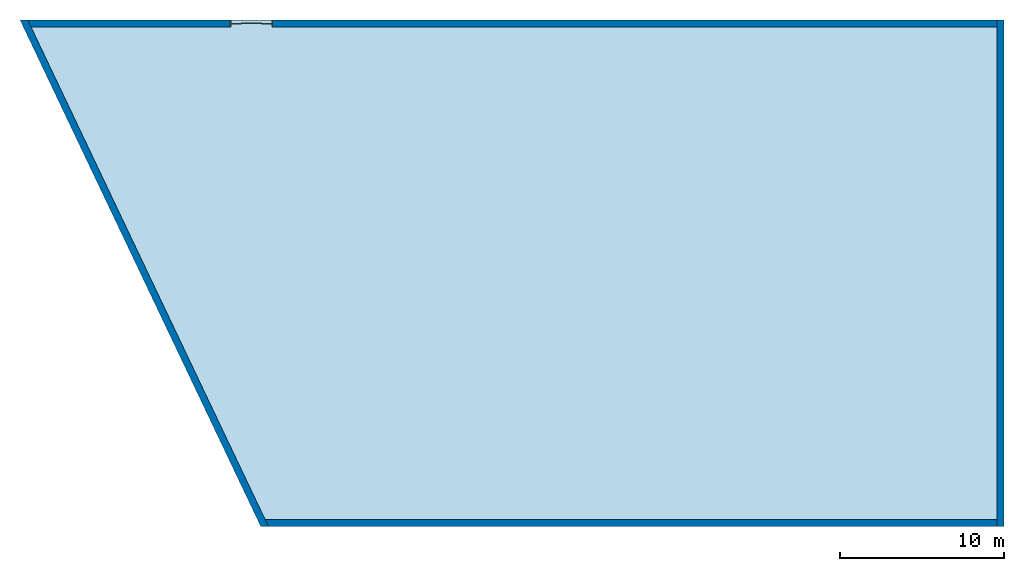
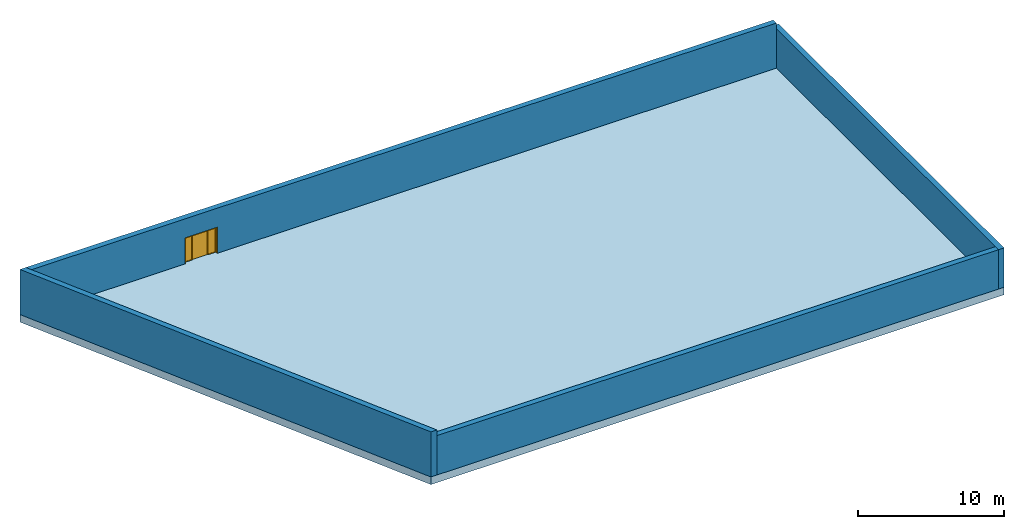
# One storey: 4 walls, 1 door, 1 slab, 1 opening.
"""IFC2X3 building model written with IfcOpenShell, lengths in metres."""

from ifc_helpers import new_model, entity, si_unit, converted_unit, derived_unit, direction, frame, frame_2d, origin, origin_2d_with_axis, place, context, subcontext, project, spatial, polyline, rectangle, outline, extrude, faceted_brep, source, transform, mapped, material, material_list, layer, layer_set, layer_usage, type_object, type_shapes, element, fill, save


model = new_model("IFC2X3")

# Units and contexts
model_context = context("Model", 3, precision=1e-05, world=origin(), true_north=direction((6.123031769111886e-17, 1.0)))
body_context = subcontext(model_context, "Body", "Model", "MODEL_VIEW")
ifc_project = project(units=[si_unit("LENGTHUNIT", "METRE"), si_unit("AREAUNIT", "SQUARE_METRE"), si_unit("VOLUMEUNIT", "CUBIC_METRE"), converted_unit("PLANEANGLEUNIT", "DEGREE", entity("IfcRatioMeasure", 0.017453292519943278), si_unit("PLANEANGLEUNIT", "RADIAN"), dimensions=[0, 0, 0, 0, 0, 0, 0]), si_unit("MASSUNIT", "GRAM", prefix="KILO"), derived_unit("MASSDENSITYUNIT", [(si_unit("MASSUNIT", "GRAM", prefix="KILO"), 1), (si_unit("LENGTHUNIT", "METRE"), -3)]), derived_unit("IONCONCENTRATIONUNIT", [(si_unit("MASSUNIT", "GRAM", prefix="KILO"), 1), (si_unit("LENGTHUNIT", "METRE"), -3)]), derived_unit("MOMENTOFINERTIAUNIT", [(si_unit("LENGTHUNIT", "METRE"), 4)]), si_unit("TIMEUNIT", "SECOND"), si_unit("FREQUENCYUNIT", "HERTZ"), si_unit("THERMODYNAMICTEMPERATUREUNIT", "DEGREE_CELSIUS"), derived_unit("THERMALTRANSMITTANCEUNIT", [(si_unit("MASSUNIT", "GRAM", prefix="KILO"), 1), (si_unit("THERMODYNAMICTEMPERATUREUNIT", "KELVIN"), -1), (si_unit("TIMEUNIT", "SECOND"), -3)]), derived_unit("THERMALCONDUCTANCEUNIT", [(si_unit("MASSUNIT", "GRAM", prefix="KILO"), 1), (si_unit("THERMODYNAMICTEMPERATUREUNIT", "KELVIN"), -1), (si_unit("TIMEUNIT", "SECOND"), -3), (si_unit("LENGTHUNIT", "METRE"), 1)]), derived_unit("VOLUMETRICFLOWRATEUNIT", [(si_unit("LENGTHUNIT", "METRE"), 3), (si_unit("TIMEUNIT", "SECOND"), -1)]), derived_unit("MASSFLOWRATEUNIT", [(si_unit("MASSUNIT", "GRAM", prefix="KILO"), 1), (si_unit("TIMEUNIT", "SECOND"), -1)]), derived_unit("ROTATIONALFREQUENCYUNIT", [(si_unit("TIMEUNIT", "SECOND"), -1)]), si_unit("ELECTRICCURRENTUNIT", "AMPERE"), si_unit("ELECTRICVOLTAGEUNIT", "VOLT"), si_unit("POWERUNIT", "WATT"), si_unit("FORCEUNIT", "NEWTON", prefix="KILO"), si_unit("ILLUMINANCEUNIT", "LUX"), si_unit("LUMINOUSFLUXUNIT", "LUMEN"), si_unit("LUMINOUSINTENSITYUNIT", "CANDELA"), derived_unit("USERDEFINED", [(si_unit("MASSUNIT", "GRAM", prefix="KILO"), -1), (si_unit("LENGTHUNIT", "METRE"), -2), (si_unit("TIMEUNIT", "SECOND"), 3), (si_unit("LUMINOUSFLUXUNIT", "LUMEN"), 1)]), derived_unit("USERDEFINED", [(si_unit("MASSUNIT", "GRAM", prefix="KILO"), 1), (si_unit("TIMEUNIT", "SECOND"), -3), (si_unit("LENGTHUNIT", "METRE"), 3), (si_unit("ELECTRICCURRENTUNIT", "AMPERE"), -2)]), derived_unit("SOUNDPOWERUNIT", [(si_unit("MASSUNIT", "GRAM", prefix="KILO"), 1), (si_unit("TIMEUNIT", "SECOND"), -3), (si_unit("LENGTHUNIT", "METRE"), 2)]), derived_unit("SOUNDPRESSUREUNIT", [(si_unit("MASSUNIT", "GRAM", prefix="KILO"), 1), (si_unit("LENGTHUNIT", "METRE"), -1), (si_unit("TIMEUNIT", "SECOND"), -2)]), derived_unit("LINEARVELOCITYUNIT", [(si_unit("LENGTHUNIT", "METRE"), 1), (si_unit("TIMEUNIT", "SECOND"), -1)]), si_unit("PRESSUREUNIT", "PASCAL"), derived_unit("USERDEFINED", [(si_unit("MASSUNIT", "GRAM", prefix="KILO"), 1), (si_unit("LENGTHUNIT", "METRE"), -2), (si_unit("TIMEUNIT", "SECOND"), -2)]), derived_unit("LINEARFORCEUNIT", [(si_unit("MASSUNIT", "GRAM", prefix="KILO"), 1), (si_unit("TIMEUNIT", "SECOND"), -2)]), derived_unit("PLANARFORCEUNIT", [(si_unit("MASSUNIT", "GRAM", prefix="KILO"), 1), (si_unit("LENGTHUNIT", "METRE"), -1), (si_unit("TIMEUNIT", "SECOND"), -2)]), derived_unit("SPECIFICHEATCAPACITYUNIT", [(si_unit("THERMODYNAMICTEMPERATUREUNIT", "KELVIN"), -1), (si_unit("LENGTHUNIT", "METRE"), 2), (si_unit("TIMEUNIT", "SECOND"), -2)]), derived_unit("HEATINGVALUEUNIT", [(si_unit("LENGTHUNIT", "METRE"), 2), (si_unit("TIMEUNIT", "SECOND"), -2)]), derived_unit("VAPORPERMEABILITYUNIT", [(si_unit("LENGTHUNIT", "METRE"), -1), (si_unit("TIMEUNIT", "SECOND"), 1)]), derived_unit("DYNAMICVISCOSITYUNIT", [(si_unit("MASSUNIT", "GRAM", prefix="KILO"), 1), (si_unit("TIMEUNIT", "SECOND"), -1), (si_unit("LENGTHUNIT", "METRE"), -1)]), derived_unit("THERMALEXPANSIONCOEFFICIENTUNIT", [(si_unit("THERMODYNAMICTEMPERATUREUNIT", "KELVIN"), -1)]), derived_unit("MODULUSOFELASTICITYUNIT", [(si_unit("MASSUNIT", "GRAM", prefix="KILO"), 1), (si_unit("LENGTHUNIT", "METRE"), -1), (si_unit("TIMEUNIT", "SECOND"), -2)]), derived_unit("ISOTHERMALMOISTURECAPACITYUNIT", [(si_unit("LENGTHUNIT", "METRE"), 3), (si_unit("MASSUNIT", "GRAM", prefix="KILO"), -1)]), derived_unit("MOISTUREDIFFUSIVITYUNIT", [(si_unit("TIMEUNIT", "SECOND"), -1), (si_unit("LENGTHUNIT", "METRE"), 2)])], contexts=[model_context])

# Site, building, storey
site_placement = place(None, frame((83.18260837531514, 5.722313863433043, -0.3219974716737357), z_axis=(0.0, 0.0, 1.0), x_axis=(0.31599863684750407, -0.9487596436982969, 0.0)))
site = spatial("IfcSite", under=ifc_project, at=site_placement, CompositionType="ELEMENT")
building_placement = place(site_placement, origin())
building = spatial("IfcBuilding", under=site, at=building_placement, CompositionType="ELEMENT")
storey_placement = place(building_placement, frame((0.0, 0.0, -7.478002528326264)))
storey = spatial("IfcBuildingStorey", under=building, at=storey_placement, CompositionType="ELEMENT", Elevation=-7.478002528326264)

# Slab
ifc_material_1 = material()
ifc_layer_1 = layer(ifc_material_1, 0.005)
ifc_material_2 = material()
ifc_layer_2 = layer(ifc_material_2, 0.08)
ifc_material_3 = material()
ifc_layer_3 = layer(ifc_material_3, 0.2)
ifc_material_4 = material()
ifc_layer_4 = layer(ifc_material_4, 0.35)
ifc_layer_set_1 = layer_set([ifc_layer_1, ifc_layer_2, ifc_layer_3, ifc_layer_4])
ifc_layer_usage_1 = layer_usage(ifc_layer_set_1, "AXIS3", "POSITIVE", 0.0)
slab_type = type_object("IfcSlabType", PredefinedType="FLOOR", material=ifc_layer_set_1)
slab_placement = place(storey_placement, origin())
element("IfcSlab", 1, at=slab_placement, inside=storey, type_object=slab_type, material=ifc_layer_usage_1, PredefinedType="FLOOR", context=body_context, shape_type="SweptSolid", body=[
    extrude(outline(polyline([(-15.437583681632269, -26.331015801751978), (15.437583682817348, -26.331015801751978), (15.437583682817426, 18.993704010185013), (-15.437583684002513, 33.66832759331895), (-15.437583681632269, -26.331015801751978)])), frame((-16.178200656982813, -52.623733880741646, 0.0), z_axis=(0.0, 0.0, -1.0), x_axis=(0.9487590375396322, -0.31600045678269334, 0.0)), (0.0, 0.0, 1.0), 0.6349999999999997),
])

# Walls
ifc_layer_5 = layer(ifc_material_4, 0.29999999999999993)
ifc_material_5 = material(Name="Rigid insulation")
ifc_layer_6 = layer(ifc_material_5, 0.12499999999999999)
ifc_layer_set_2 = layer_set([ifc_layer_5, ifc_layer_6], Name="Basic Wall:CAVE_M-cave-01 (")
ifc_layer_usage_2 = layer_usage(ifc_layer_set_2, "AXIS2", "NEGATIVE", 0.21249999999999994)
wall_type = type_object("IfcWallType", Name="Basic Wall:CAVE_M-cave-01 (", PredefinedType="STANDARD", material=ifc_layer_set_2)
wall_1_placement = place(storey_placement, frame((6.721809303704131, -32.72183946209911, 0.0), z_axis=(0.0, 0.0, 1.0), x_axis=(-0.9487590375396322, 0.3160004567826936, 0.0)))
element("IfcWallStandardCase", 2, at=wall_1_placement, inside=storey, type_object=wall_type, material=ifc_layer_usage_2, Name="Basic Wall:CAVE_M-cave-01 (", ObjectType="Basic Wall:CAVE_M-cave-01 (", context=body_context, shape_type="SweptSolid", body=[
    extrude(rectangle(XDim=30.875167364449617, YDim=0.42499999999999544, at=frame_2d((2.800426557314495e-12, -0.0708333333333305), x_axis=(1.0, 0.0))), frame((15.43758368223041, 0.07083333333333455, 0.0)), (0.0, 0.0, 1.0), 3.2899999999999974),
])
wall_2_placement = place(storey_placement, frame((-41.489851829026286, -79.47766441075834, 0.0), z_axis=(0.0, 0.0, 1.0), x_axis=(0.992546151641322, 0.12186934340514734, 0.0)))
element("IfcWallStandardCase", 3, at=wall_2_placement, inside=storey, type_object=wall_type, material=ifc_layer_usage_2, Name="Basic Wall:CAVE_M-cave-01 (", ObjectType="Basic Wall:CAVE_M-cave-01 (", context=body_context, shape_type="SweptSolid", body=[
    extrude(outline(polyline([(-17.227211343700098, -0.2833333333334054), (16.9578809808178, -0.28333333333326705), (17.159878752967014, 0.14166666666674113), (16.689317279880626, 0.14166666666674274), (-16.55465209843506, 0.14166666666660901), (-17.02521357153029, 0.14166666666661415), (-17.227211343700098, -0.2833333333334054)])), frame((17.227211343700098, 0.07083333333334323, 0.0)), (0.0, 0.0, 1.0), 3.7699999999999974),
])
wall_3_placement = place(storey_placement, frame((-7.650417806654925, -75.2005133766632, 0.0), z_axis=(0.0, 0.0, 1.0), x_axis=(0.31600045678269195, 0.9487590375396326, 0.0)))
element("IfcWallStandardCase", 4, at=wall_3_placement, inside=storey, type_object=wall_type, material=ifc_layer_usage_2, Name="Basic Wall:CAVE_M-cave-01 (", ObjectType="Basic Wall:CAVE_M-cave-01 (", context=body_context, shape_type="SweptSolid", body=[
    extrude(outline(polyline([(-22.164079726387982, -0.2124999999996669), (22.265078612462588, -0.2125000000003307), (22.265078612462588, 0.21249999999966582), (-22.366077498537194, 0.2125000000003307), (-22.164079726387982, -0.2124999999996669)])), frame((22.36607749853719, 0.0, 0.0)), (0.0, 0.0, 1.0), 3.2899999999999974),
])

# Wall, opening, door
wall_4_placement = place(storey_placement, frame((-22.43682357046857, -23.234033864221146, 0.0), z_axis=(0.0, 0.0, 1.0), x_axis=(-0.3160004568201735, -0.9487590375271486, 0.0)))
wall_4 = element("IfcWall", 5, at=wall_4_placement, inside=storey, type_object=wall_type, Name="Basic Wall:CAVE_M-cave-01 (", ObjectType="Basic Wall:CAVE_M-cave-01 (", context=body_context, shape_type="Brep", body=[
    faceted_brep([(0.0, -0.21249999999999933, 0.0), (0.0, 0.21250000000000258, 0.0), (44.17999999992445, 0.212499999999982, 0.0), (44.179999999924455, -0.212499999999995, 0.0), (59.10378192199245, -0.21250000000000366, 3.7699999999999996), (0.0, -0.21249999999999933, 3.7699999999999996), (0.0, -0.21249999999999933, 3.289999999999999), (44.179999999924455, -0.212499999999995, 2.183), (46.75999999992445, -0.212499999999995, 2.183), (46.75999999992445, -0.21249999999999933, 0.0), (59.10378192199245, -0.212499999999995, 0.0), (58.90178414982267, 0.21250000000000802, 3.7699999999999996), (0.0, 0.21250000000000258, 3.7699999999999996), (58.90178414982267, 0.21249999999999933, 0.0), (46.75999999992445, 0.21249999999999933, 0.0), (46.75999999992445, 0.21249999999999933, 2.183), (44.179999999924455, 0.21250000000000802, 2.183)], [[[0, 1, 2, 3]], [[4, 5, 6, 0, 3, 7, 8, 9, 10]], [[5, 4, 11, 12]], [[12, 11, 13, 14, 15, 16, 2, 1]], [[13, 11, 4, 10]], [[8, 15, 14, 9]], [[15, 8, 7, 16]], [[16, 7, 3, 2]], [[1, 0, 6, 5, 12]], [[13, 10, 9, 14]]]),
])
opening_placement = place(wall_4_placement, frame((46.75999999992447, 0.21249999999999933, 0.0)))
opening = element("IfcOpeningElement", 6, at=opening_placement, cuts=wall_4, Name="Sliding Door - 4 Panel (AUS):Type 1:1", ObjectType="Opening", context=body_context, shape_type="SweptSolid", body=[
    extrude(rectangle(XDim=2.1830000000000003, YDim=2.5799999999999996, at=frame_2d((1.0915000000000004, 1.2900000000000011), x_axis=(1.0, 0.0))), frame((0.0, 0.0, 0.0), z_axis=(0.0, -1.0, 0.0), x_axis=(0.0, 0.0, 1.0)), (0.0, 0.0, 1.0), 0.4249999999999999),
])
ifc_material_6 = material(Name="Sliding Door Glass")
ifc_material_7 = material(Name="Sliding Door Frame")
ifc_material_list = material_list([ifc_material_6, ifc_material_7])
door_style = type_object("IfcDoorStyle", Name="Sliding Door - 4 Panel (AUS):Type 1", ConstructionType="NOTDEFINED", OperationType="NOTDEFINED", ParameterTakesPrecedence=False, Sizeable=False, material=ifc_material_list)
shared_shape = source(origin(), body_context, "Body", "SweptSolid", [
    extrude(rectangle(XDim=0.5287499999999998, YDim=0.01333333333333333, at=frame_2d((-8.326672684688674e-17, 0.0), x_axis=(1.0, 0.0))), frame((2.2206249999999987, 0.19249999999999995, 0.05499999999999999), z_axis=(0.0, 0.0, 1.0), x_axis=(-1.0, 0.0, 0.0)), (0.0, 0.0, 1.0), 2.0329999999999995),
    extrude(outline(polyline([(-0.31937499999999996, -1.0715), (0.3193749999999998, -1.0715), (0.31937499999999996, 1.0715), (-0.31937499999999996, 1.0715), (-0.31937499999999996, -1.0715)]), holes=[polyline([(-0.264375, -1.0164999999999997), (-0.264375, 1.0164999999999997), (0.26437499999999986, 1.0164999999999997), (0.26437499999999986, -1.0164999999999997), (-0.264375, -1.0164999999999997)])]), frame((2.2206249999999987, 0.1725, 1.0715), z_axis=(0.0, 1.0, 0.0), x_axis=(-1.0, 0.0, 0.0)), (0.0, 0.0, 1.0), 0.039999999999999994),
    extrude(rectangle(XDim=0.5287499999999997, YDim=0.01333333333333333, at=frame_2d((-2.7755575615628914e-17, 0.0), x_axis=(1.0, 0.0))), frame((1.609374999999998, 0.23249999999999993, 0.05499999999999999), z_axis=(0.0, 0.0, 1.0), x_axis=(-1.0, 0.0, 0.0)), (0.0, 0.0, 1.0), 2.0329999999999995),
    extrude(outline(polyline([(-0.31937499999999996, -1.0715), (0.3193749999999998, -1.0715), (0.31937499999999996, 1.0715), (-0.3193749999999998, 1.0715), (-0.31937499999999996, -1.0715)]), holes=[polyline([(-0.26437499999999986, -1.0164999999999997), (-0.26437499999999986, 1.0164999999999997), (0.26437499999999986, 1.0164999999999997), (0.26437499999999986, -1.0164999999999997), (-0.26437499999999986, -1.0164999999999997)])]), frame((1.609374999999998, 0.21249999999999994, 1.0715), z_axis=(0.0, 1.0, 0.0), x_axis=(-1.0, 0.0, 0.0)), (0.0, 0.0, 1.0), 0.039999999999999994),
    extrude(rectangle(XDim=0.5287499999999997, YDim=0.01333333333333333, at=origin_2d_with_axis()), frame((0.9706249999999984, 0.23249999999999993, 0.05499999999999999), z_axis=(0.0, 0.0, 1.0), x_axis=(-1.0, 0.0, 0.0)), (0.0, 0.0, 1.0), 2.0329999999999995),
    extrude(outline(polyline([(-0.31937499999999996, -1.0715), (0.3193749999999998, -1.0715), (0.31937499999999996, 1.0715), (-0.3193749999999999, 1.0715), (-0.31937499999999996, -1.0715)]), holes=[polyline([(-0.26437499999999986, -1.0164999999999997), (-0.2643749999999999, 1.0164999999999997), (0.26437499999999986, 1.0164999999999997), (0.26437499999999986, -1.0164999999999997), (-0.26437499999999986, -1.0164999999999997)])]), frame((0.9706249999999984, 0.21249999999999994, 1.0715), z_axis=(0.0, 1.0, 0.0), x_axis=(-1.0, 0.0, 0.0)), (0.0, 0.0, 1.0), 0.039999999999999994),
    extrude(rectangle(XDim=0.5287499999999998, YDim=0.01333333333333333, at=frame_2d((-1.3877787807814457e-16, 0.0), x_axis=(1.0, 0.0))), frame((0.3593749999999992, 0.19249999999999995, 0.05499999999999999), z_axis=(0.0, 0.0, 1.0), x_axis=(-1.0, 0.0, 0.0)), (0.0, 0.0, 1.0), 2.0329999999999995),
    extrude(outline(polyline([(-0.3193749999999998, -1.0715), (0.31937499999999996, -1.0715), (0.3193750000000001, 1.0715), (-0.31937499999999974, 1.0715), (-0.3193749999999998, -1.0715)]), holes=[polyline([(-0.26437499999999975, -1.0164999999999997), (-0.26437499999999975, 1.0164999999999997), (0.264375, 1.0164999999999997), (0.264375, -1.0164999999999997), (-0.26437499999999975, -1.0164999999999997)])]), frame((0.3593749999999995, 0.1725, 1.0715), z_axis=(0.0, 1.0, 0.0), x_axis=(-1.0, 0.0, 0.0)), (0.0, 0.0, 1.0), 0.039999999999999994),
    extrude(outline(polyline([(-1.0815, -1.2899999999999996), (1.1015000000000006, -1.2899999999999996), (1.1015000000000001, 1.2899999999999996), (-1.0815000000000001, 1.2899999999999996), (-1.0815000000000001, 1.2499999999999993), (1.0614999999999997, 1.2499999999999993), (1.0615, -1.2499999999999993), (-1.0815, -1.2499999999999993), (-1.0815, -1.2899999999999996)])), frame((1.2899999999999996, 0.0, 1.0815), z_axis=(0.0, 1.0, 0.0), x_axis=(0.0, 0.0, 1.0)), (0.0, 0.0, 1.0), 0.4249999999999999),
])
type_shapes(door_style, [shared_shape])
door_placement = place(opening_placement, frame((0.0, 0.0, 0.0), z_axis=(0.0, 0.0, 1.0), x_axis=(-1.0, 0.0, 0.0)))
door = element("IfcDoor", 7, at=door_placement, inside=storey, type_object=door_style, material=ifc_material_list, Name="Sliding Door - 4 Panel (AUS):Type 1", ObjectType="Sliding Door - 4 Panel (AUS):Type 1", OverallHeight=2.183, OverallWidth=2.5799999999999863, context=body_context, shape_type="MappedRepresentation", body=[
    mapped(shared_shape, transform((0.0, 0.0, 0.0), scale=1.0)),
])
fill(opening, door)

save(model, "model.ifc")
